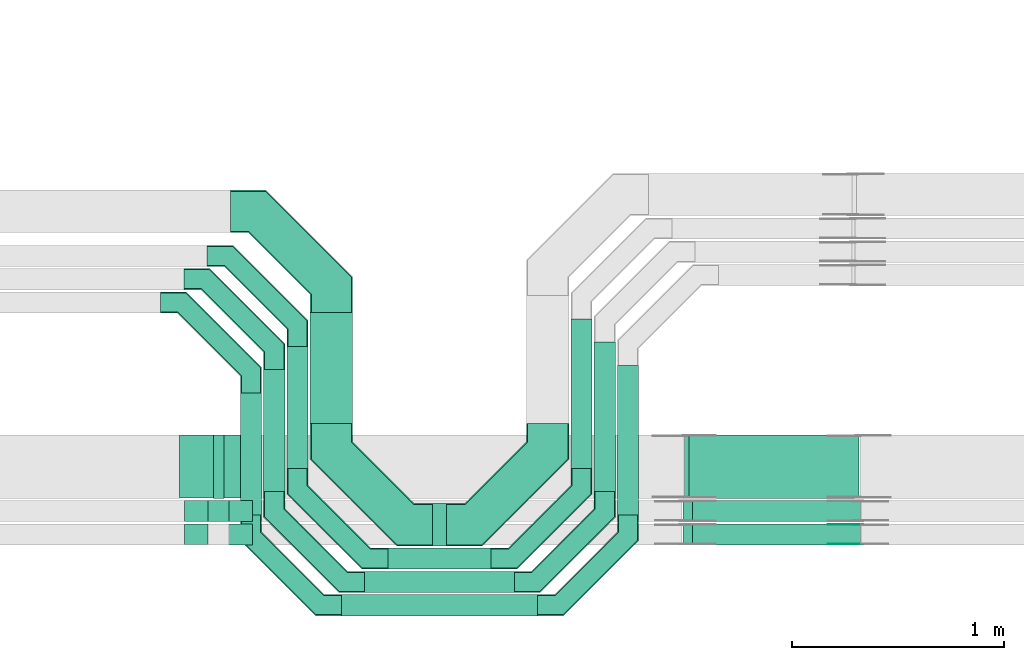
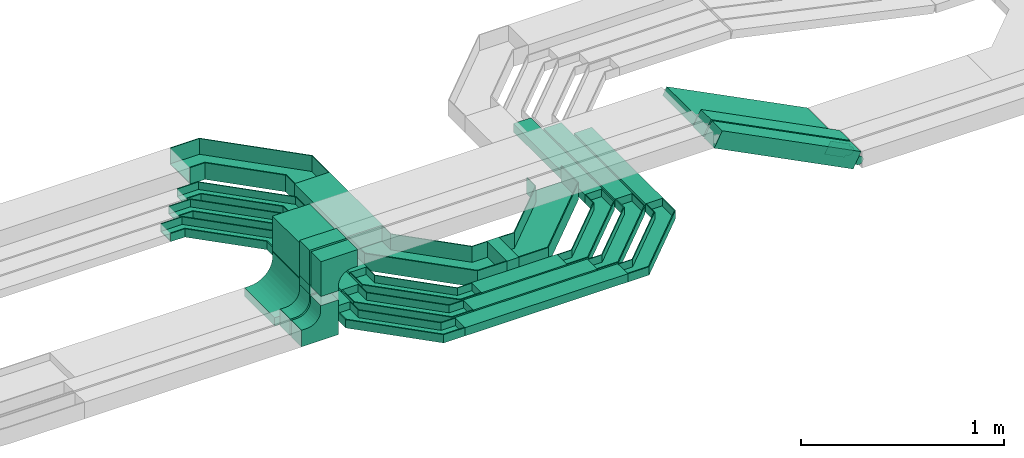
# One storey, part 14 of 33: 20 flow fittings, 16 flow segments.
"""IFC2X3 building model written with IfcOpenShell, lengths in millimetres."""

import ifcopenshell
import ifcopenshell.guid

model = None  # the IFC model being written
_history = None  # IfcOwnerHistory: only IFC2X3 demands one
_inside = {}  # id of a spatial element -> (the spatial element, [elements in it])
_under = {}  # id of a project, library or spatial element -> (it, [spatial elements below it])
_declared = {}  # id of a project -> (the project, [libraries it declares])
_typed = {}  # id of a type object -> (the type object, [elements of that type])
_made_of = {}  # id of a material, layer set ... -> (it, [elements and type objects made of it])


def new_model(schema):
    """Start an empty IFC model of exactly this schema.

    Asked for "IFC4X3", IfcOpenShell would pick the latest addendum, in which some entities
    have other attributes; the version numbers below select the first issue.
    IFC2X3 requires an IfcOwnerHistory on every rooted entity: one is made here for all.
    """
    global model, _history
    if schema == "IFC4X3":
        model = ifcopenshell.file(schema_version=(4, 3, 0, 0))
    else:
        model = ifcopenshell.file(schema=schema)
    _inside.clear()
    _under.clear()
    _declared.clear()
    _typed.clear()
    _made_of.clear()
    _history = None
    if model.schema == "IFC2X3":
        org = make("IfcOrganization", Name="unknown")
        user = make(
            "IfcPersonAndOrganization",
            ThePerson=make("IfcPerson", FamilyName="unknown"),
            TheOrganization=org,
        )
        app = make(
            "IfcApplication",
            ApplicationDeveloper=org,
            Version="unknown",
            ApplicationFullName="unknown",
            ApplicationIdentifier="unknown",
        )
        _history = make(
            "IfcOwnerHistory",
            OwningUser=user,
            OwningApplication=app,
            ChangeAction="ADDED",
            CreationDate=0,
        )
    return model


def make(cls, **values):
    """One entity of the class cls with the attributes given. An attribute that is None is left unset."""
    return model.create_entity(
        cls, **{name: value for name, value in values.items() if value is not None}
    )


def entity(cls, *values):
    """Any entity or typed value of the class cls, its attributes in the order of the schema. None: left unset."""
    e = model.create_entity(cls)
    for i, value in enumerate(values):
        if value is not None:
            e[i] = value
    return e


def rooted(cls, **values):
    """An entity with a GlobalId (a new one), such as an element, a storey or a relation."""
    return make(cls, GlobalId=ifcopenshell.guid.new(), OwnerHistory=_history, **values)


def si_unit(unit_type, name, prefix=None):
    """IfcSIUnit, for example si_unit("LENGTHUNIT", "METRE", prefix="MILLI")."""
    return make("IfcSIUnit", UnitType=unit_type, Prefix=prefix, Name=name)


def converted_unit(unit_type, name, factor, base, dimensions=None, offset=None):
    """IfcConversionBasedUnit, such as the inch: factor (a typed value) times the base unit."""
    return make(
        "IfcConversionBasedUnit"
        if offset is None
        else "IfcConversionBasedUnitWithOffset",
        ConversionOffset=offset,
        Dimensions=None
        if dimensions is None
        else entity("IfcDimensionalExponents", *dimensions),
        UnitType=unit_type,
        Name=name,
        ConversionFactor=make(
            "IfcMeasureWithUnit", ValueComponent=factor, UnitComponent=base
        ),
    )


def derived_unit(unit_type, elements):
    """IfcDerivedUnit: a product of units, each with its exponent."""
    return make(
        "IfcDerivedUnit",
        Elements=[
            make("IfcDerivedUnitElement", Unit=unit, Exponent=power)
            for unit, power in elements
        ],
        UnitType=unit_type,
    )


def assignment(units):
    """IfcUnitAssignment: the units of a project."""
    return None if units is None else make("IfcUnitAssignment", Units=units)


def point(xyz):
    """IfcCartesianPoint."""
    return None if xyz is None else make("IfcCartesianPoint", Coordinates=xyz)


def direction(xyz):
    """IfcDirection."""
    return None if xyz is None else make("IfcDirection", DirectionRatios=xyz)


def frame(location, z_axis=None, x_axis=None):
    """IfcAxis2Placement3D, a coordinate frame: its origin and axes. An axis left out is left unset."""
    return make(
        "IfcAxis2Placement3D",
        Location=point(location),
        Axis=direction(z_axis),
        RefDirection=direction(x_axis),
    )


def frame_2d(location, x_axis=None):
    """IfcAxis2Placement2D, a coordinate frame in the plane: its origin and x axis."""
    return make(
        "IfcAxis2Placement2D", Location=point(location), RefDirection=direction(x_axis)
    )


def origin():
    """The frame at (0, 0, 0) with its axes left unset."""
    return frame((0.0, 0.0, 0.0))


def origin_2d_with_axis():
    """The frame at (0, 0) in the plane with the x axis (1, 0) written out."""
    return frame_2d((0.0, 0.0), x_axis=(1.0, 0.0))


def place(relative_to, where):
    """IfcLocalPlacement: puts the frame where relative to a parent placement (None: the world)."""
    return make(
        "IfcLocalPlacement", PlacementRelTo=relative_to, RelativePlacement=where
    )


def context(
    kind, dimensions, precision=None, world=None, true_north=None, identifier=None
):
    """IfcGeometricRepresentationContext, for example the 3D "Model" context."""
    return make(
        "IfcGeometricRepresentationContext",
        ContextIdentifier=identifier,
        ContextType=kind,
        CoordinateSpaceDimension=dimensions,
        Precision=precision,
        WorldCoordinateSystem=world,
        TrueNorth=true_north,
    )


def subcontext(parent, identifier, kind, view, scale=None):
    """IfcGeometricRepresentationSubContext, for example "Body" below "Model"."""
    return make(
        "IfcGeometricRepresentationSubContext",
        ContextIdentifier=identifier,
        ContextType=kind,
        ParentContext=parent,
        TargetScale=scale,
        TargetView=view,
    )


def project(units=None, contexts=None):
    """IfcProject with its units and contexts."""
    return rooted(
        "IfcProject",
        Name="project",
        RepresentationContexts=contexts,
        UnitsInContext=assignment(units),
    )


def spatial(cls, under=None, at=None, **own):
    """A site, building, storey or space (cls), placed at a placement, below another one or the project."""
    s = rooted(cls, ObjectPlacement=at, **own)
    if under is not None:
        _under.setdefault(under.id(), (under, []))[1].append(s)
    return s


def polyline(points):
    """IfcPolyline through the points."""
    return make("IfcPolyline", Points=[point(p) for p in points])


def circle_curve(where, radius):
    """IfcCircle in the frame where."""
    return make("IfcCircle", Position=where, Radius=radius)


def parameter(value):
    """IfcParameterValue: where a trimmed curve begins or ends, as a parameter of its basis curve."""
    return model.create_entity("IfcParameterValue", value)


def trimmed(basis, trim1, trim2, sense, master):
    """IfcTrimmedCurve: the piece of a basis curve between two trims."""
    return make(
        "IfcTrimmedCurve",
        BasisCurve=basis,
        Trim1=trim1,
        Trim2=trim2,
        SenseAgreement=sense,
        MasterRepresentation=master,
    )


def segment(curve, same_sense, transition):
    """IfcCompositeCurveSegment."""
    return make(
        "IfcCompositeCurveSegment",
        Transition=transition,
        SameSense=same_sense,
        ParentCurve=curve,
    )


def composite_curve(segments, self_intersect=None):
    """IfcCompositeCurve: segments joined end to end."""
    return make("IfcCompositeCurve", Segments=segments, SelfIntersect=self_intersect)


def profile(cls, at=None, kind="AREA", **sizes):
    """A parametric profile (cls). Its sizes go by their IFC names, for example OverallWidth=200.0."""
    return make(cls, ProfileType=kind, Position=at, **sizes)


def rectangle(**sizes):
    """IfcRectangleProfileDef."""
    return profile("IfcRectangleProfileDef", **sizes)


def outline(outer, holes=None, kind="AREA"):
    """IfcArbitraryClosedProfileDef: a profile drawn as a closed curve; with holes, ...WithVoids."""
    if holes is None:
        return make("IfcArbitraryClosedProfileDef", ProfileType=kind, OuterCurve=outer)
    return make(
        "IfcArbitraryProfileDefWithVoids",
        ProfileType=kind,
        OuterCurve=outer,
        InnerCurves=holes,
    )


def extrude(swept, where, along, depth):
    """IfcExtrudedAreaSolid: the profile swept, set in the frame where, extruded along a direction by depth."""
    return make(
        "IfcExtrudedAreaSolid",
        SweptArea=swept,
        Position=where,
        ExtrudedDirection=direction(along),
        Depth=depth,
    )


def faces_of(points, faces, orient=None, outer=None):
    """IfcFace entities. A face is a list of loops; a loop is a list of indices into points, from 0.

    orient and outer hold one flag for each loop. By default every Orientation is true, the
    first loop of a face is its IfcFaceOuterBound and the others are IfcFaceBound.
    """
    made = []
    for i, loops in enumerate(faces):
        bounds = []
        for j, loop in enumerate(loops):
            is_outer = j == 0 if outer is None else outer[i][j]
            bounds.append(
                make(
                    "IfcFaceOuterBound" if is_outer else "IfcFaceBound",
                    Bound=make("IfcPolyLoop", Polygon=[points[k] for k in loop]),
                    Orientation=True if orient is None else orient[i][j],
                )
            )
        made.append(make("IfcFace", Bounds=bounds))
    return made


def faceted_brep(points, faces, orient=None, outer=None, voids=None):
    """IfcFacetedBrep: a solid bounded by flat faces; with voids (closed shells), ...WithVoids."""
    shared = [point(p) for p in points]
    hull = make("IfcClosedShell", CfsFaces=faces_of(shared, faces, orient, outer))
    if voids is None:
        return make("IfcFacetedBrep", Outer=hull)
    return make(
        "IfcFacetedBrepWithVoids",
        Outer=hull,
        Voids=[
            make(cls, CfsFaces=faces_of(shared, fs, o, b)) for cls, fs, o, b in voids
        ],
    )


def shape(context_of_items, identifier, shape_type, items):
    """IfcShapeRepresentation: the items that make up one representation, for example the "Body"."""
    return make(
        "IfcShapeRepresentation",
        ContextOfItems=context_of_items,
        RepresentationIdentifier=identifier,
        RepresentationType=shape_type,
        Items=items,
    )


def source(mapping_origin, context_of_items, identifier, shape_type, items):
    """IfcRepresentationMap: a shape defined once, which mapped items show again and again."""
    return make(
        "IfcRepresentationMap",
        MappingOrigin=mapping_origin,
        MappedRepresentation=shape(context_of_items, identifier, shape_type, items),
    )


def transform(
    local_origin,
    x_axis=None,
    y_axis=None,
    z_axis=None,
    scale=None,
    scale2=None,
    scale3=None,
    uniform=True,
):
    """IfcCartesianTransformationOperator3D, or its non-uniform kind. x_axis, y_axis, z_axis: its Axis1, 2, 3."""
    if uniform:
        return make(
            "IfcCartesianTransformationOperator3D",
            Axis1=direction(x_axis),
            Axis2=direction(y_axis),
            LocalOrigin=point(local_origin),
            Scale=scale,
            Axis3=direction(z_axis),
        )
    return make(
        "IfcCartesianTransformationOperator3DnonUniform",
        Axis1=direction(x_axis),
        Axis2=direction(y_axis),
        LocalOrigin=point(local_origin),
        Scale=scale,
        Axis3=direction(z_axis),
        Scale2=scale2,
        Scale3=scale3,
    )


def mapped(mapping_source, mapping_target):
    """IfcMappedItem: shows the shape of a source again, moved by a transform."""
    return make(
        "IfcMappedItem", MappingSource=mapping_source, MappingTarget=mapping_target
    )


def material(Name=None, Category=None):
    """IfcMaterial."""
    return make("IfcMaterial", Name=Name, Category=Category)


def made_of(thing, what):
    """Note that an element or type object is made of a material, layer set ...; save() writes the relation."""
    if what is not None:
        _made_of.setdefault(what.id(), (what, []))[1].append(thing)
    return thing


def type_object(cls, material=None, **own):
    """A type object (cls), such as IfcWallType, which elements share."""
    return made_of(rooted(cls, **own), material)


def type_shapes(of_type, sources):
    """Give a type object the sources (RepresentationMaps) that its elements show as mapped items."""
    of_type.RepresentationMaps = sources


def element(
    cls,
    number,
    at=None,
    inside=None,
    cuts=None,
    type_object=None,
    material=None,
    context=None,
    identifier="Body",
    shape_type=None,
    held_by="IfcProductDefinitionShape",
    body=None,
    shapes=None,
    **own,
):
    """One element of the class cls, such as IfcWall. Its Tag is "e" and its number.

    at: its placement. inside: the storey or other place that contains it. cuts: it is an
    opening in that element (IfcRelVoidsElement). A single representation is given by context,
    identifier, shape_type and body (its items); several are given by shapes. held_by: the class
    of the entity that holds the representations. save() writes the other relations.
    """
    e = rooted(cls, Tag="e%d" % number, ObjectPlacement=at, **own)
    if body is not None:
        shapes = [shape(context, identifier, shape_type, body)]
    if shapes is not None:
        e.Representation = make(held_by, Representations=shapes)
    if inside is not None:
        _inside.setdefault(inside.id(), (inside, []))[1].append(e)
    if cuts is not None:
        rooted(
            "IfcRelVoidsElement", RelatingBuildingElement=cuts, RelatedOpeningElement=e
        )
    if type_object is not None:
        _typed.setdefault(type_object.id(), (type_object, []))[1].append(e)
    return made_of(e, material)


def aggregate(whole, parts):
    """IfcRelAggregates: a whole, such as a stair, and the parts it consists of."""
    return rooted("IfcRelAggregates", RelatingObject=whole, RelatedObjects=parts)


def save(model, path):
    """Write the relations noted so far, then the file.

    IfcRelAggregates (storeys below a building ...), IfcRelContainedInSpatialStructure (elements
    in a storey), IfcRelDefinesByType, IfcRelAssociatesMaterial and IfcRelDeclares: one each for
    every whole, place, type object, material and project.
    """
    for whole, parts in _under.values():
        aggregate(whole, parts)
    for where, things in _inside.values():
        rooted(
            "IfcRelContainedInSpatialStructure",
            RelatedElements=things,
            RelatingStructure=where,
        )
    for kind, things in _typed.values():
        rooted("IfcRelDefinesByType", RelatedObjects=things, RelatingType=kind)
    for what, things in _made_of.values():
        rooted("IfcRelAssociatesMaterial", RelatedObjects=things, RelatingMaterial=what)
    for by, libraries in _declared.values():
        rooted("IfcRelDeclares", RelatingContext=by, RelatedDefinitions=libraries)
    model.write(path)


model = new_model("IFC2X3")

# Units and contexts
model_context = context("Model", 3, precision=0.01, world=origin(), true_north=direction((6.12303176911189e-17, 1.0)))
body_context = subcontext(model_context, "Body", "Model", "MODEL_VIEW")
ifc_project = project(units=[si_unit("LENGTHUNIT", "METRE", prefix="MILLI"), si_unit("AREAUNIT", "SQUARE_METRE"), si_unit("VOLUMEUNIT", "CUBIC_METRE"), converted_unit("PLANEANGLEUNIT", "DEGREE", entity("IfcRatioMeasure", 0.0174532925199433), si_unit("PLANEANGLEUNIT", "RADIAN"), dimensions=[0, 0, 0, 0, 0, 0, 0]), si_unit("MASSUNIT", "GRAM", prefix="KILO"), derived_unit("MASSDENSITYUNIT", [(si_unit("MASSUNIT", "GRAM", prefix="KILO"), 1), (si_unit("LENGTHUNIT", "METRE"), -3)]), derived_unit("MOMENTOFINERTIAUNIT", [(si_unit("LENGTHUNIT", "METRE"), 4)]), si_unit("TIMEUNIT", "SECOND"), si_unit("FREQUENCYUNIT", "HERTZ"), si_unit("THERMODYNAMICTEMPERATUREUNIT", "DEGREE_CELSIUS"), derived_unit("THERMALTRANSMITTANCEUNIT", [(si_unit("MASSUNIT", "GRAM", prefix="KILO"), 1), (si_unit("THERMODYNAMICTEMPERATUREUNIT", "KELVIN"), -1), (si_unit("TIMEUNIT", "SECOND"), -3)]), derived_unit("VOLUMETRICFLOWRATEUNIT", [(si_unit("LENGTHUNIT", "METRE"), 3), (si_unit("TIMEUNIT", "SECOND"), -1)]), derived_unit("MASSFLOWRATEUNIT", [(si_unit("MASSUNIT", "GRAM", prefix="KILO"), 1), (si_unit("TIMEUNIT", "SECOND"), -1)]), derived_unit("ROTATIONALFREQUENCYUNIT", [(si_unit("TIMEUNIT", "SECOND"), -1)]), si_unit("ELECTRICCURRENTUNIT", "AMPERE"), si_unit("ELECTRICVOLTAGEUNIT", "VOLT"), si_unit("POWERUNIT", "WATT"), si_unit("FORCEUNIT", "NEWTON", prefix="KILO"), si_unit("ILLUMINANCEUNIT", "LUX"), si_unit("LUMINOUSFLUXUNIT", "LUMEN"), si_unit("LUMINOUSINTENSITYUNIT", "CANDELA"), derived_unit("USERDEFINED", [(si_unit("MASSUNIT", "GRAM", prefix="KILO"), -1), (si_unit("LENGTHUNIT", "METRE"), -2), (si_unit("TIMEUNIT", "SECOND"), 3), (si_unit("LUMINOUSFLUXUNIT", "LUMEN"), 1)]), derived_unit("LINEARVELOCITYUNIT", [(si_unit("LENGTHUNIT", "METRE"), 1), (si_unit("TIMEUNIT", "SECOND"), -1)]), si_unit("PRESSUREUNIT", "PASCAL"), derived_unit("USERDEFINED", [(si_unit("LENGTHUNIT", "METRE"), -2), (si_unit("MASSUNIT", "GRAM", prefix="KILO"), 1), (si_unit("TIMEUNIT", "SECOND"), -2)]), derived_unit("LINEARFORCEUNIT", [(si_unit("MASSUNIT", "GRAM", prefix="KILO"), 1), (si_unit("LENGTHUNIT", "METRE"), 1), (si_unit("TIMEUNIT", "SECOND"), -2), (si_unit("LENGTHUNIT", "METRE"), -1)]), derived_unit("PLANARFORCEUNIT", [(si_unit("MASSUNIT", "GRAM", prefix="KILO"), 1), (si_unit("LENGTHUNIT", "METRE"), 1), (si_unit("TIMEUNIT", "SECOND"), -2), (si_unit("LENGTHUNIT", "METRE"), -2)])], contexts=[model_context])

# Site, building, storey
site_placement = place(None, frame((0.0, -0.00077364408347762, 0.0)))
site = spatial("IfcSite", under=ifc_project, at=site_placement, CompositionType="ELEMENT")
building_placement = place(site_placement, origin())
building = spatial("IfcBuilding", under=site, at=building_placement, CompositionType="ELEMENT")
storey_placement = place(building_placement, frame((0.0, 0.0, 8100.0)))
storey = spatial("IfcBuildingStorey", under=building, at=storey_placement, CompositionType="ELEMENT", Elevation=8100.0)

# Flow segments
cable_carrier_segment_type = type_object("IfcCableCarrierSegmentType", PredefinedType="CABLETRAYSEGMENT")
flow_segment_1_placement = place(storey_placement, frame((30337.4684005989, 8308.01799859667, 2800.0)))
element("IfcFlowSegment", 1, at=flow_segment_1_placement, inside=storey, type_object=cable_carrier_segment_type, context=body_context, shape_type="SweptSolid", body=[
    extrude(rectangle(XDim=487.314922946357, YDim=100.000000000001, at=frame_2d((-2.1600499167107e-12, 0.0), x_axis=(1.0, 0.0))), frame((243.65746147318, 50.0, 0.0)), (0.0, 0.0, 1.0), 50.0000000000016),
])
flow_segment_2_placement = place(storey_placement, frame((30227.9450437435, 8198.49464174137, 2800.0)))
element("IfcFlowSegment", 2, at=flow_segment_2_placement, inside=storey, type_object=cable_carrier_segment_type, context=body_context, shape_type="SweptSolid", body=[
    extrude(rectangle(XDim=706.36163665698, YDim=99.9999999999989, at=frame_2d((2.1600499167107e-12, -5.40012479177676e-13), x_axis=(1.0, 0.0))), frame((353.180818328488, 50.0, 0.0)), (0.0, 0.0, 1.0), 50.0000000000016),
])
flow_segment_3_placement = place(storey_placement, frame((30117.9450437435, 8088.49464174135, 2800.0)))
element("IfcFlowSegment", 3, at=flow_segment_3_placement, inside=storey, type_object=cable_carrier_segment_type, context=body_context, shape_type="SweptSolid", body=[
    extrude(rectangle(XDim=926.361636657043, YDim=99.9999999999989, at=frame_2d((-2.1600499167107e-12, -5.40012479177676e-13), x_axis=(1.0, 0.0))), frame((463.180818328524, 50.0, 0.0)), (0.0, 0.0, 1.0), 50.0000000000016),
])
flow_segment_4_placement = place(storey_placement, frame((30547.4684005988, 8418.01799859664, 2800.0)))
element("IfcFlowSegment", 4, at=flow_segment_4_placement, inside=storey, type_object=cable_carrier_segment_type, context=body_context, shape_type="SweptSolid", body=[
    extrude(rectangle(XDim=67.3149229463092, YDim=200.0, at=frame_2d((-4.33075797445781e-12, -5.47117906535277e-13), x_axis=(1.0, 0.0))), frame((33.6574614731676, 100.0, 0.0)), (0.0, 0.0, 1.0), 99.9999999999989),
])
flow_segment_5_placement = place(storey_placement, frame((29489.4603210585, 8532.45182054437, 2999.66918252172)))
element("IfcFlowSegment", 5, at=flow_segment_5_placement, inside=storey, type_object=cable_carrier_segment_type, context=body_context, shape_type="SweptSolid", body=[
    extrude(rectangle(XDim=100.000000000001, YDim=100.000000000003, at=frame_2d((1.08357767203415e-12, -4.33431068813661e-12), x_axis=(1.0, 0.0))), frame((50.0, 50.0, 0.0), z_axis=(0.0, 0.0, 1.0), x_axis=(0.0, 1.0, 0.0)), (0.0, 0.0, 1.0), 55.3479418970819),
])
flow_segment_6_placement = place(storey_placement, frame((29514.4603210585, 8642.0466811094, 3000.01530223365)))
element("IfcFlowSegment", 6, at=flow_segment_6_placement, inside=storey, type_object=cable_carrier_segment_type, context=body_context, shape_type="SweptSolid", body=[
    extrude(rectangle(XDim=299.999999999999, YDim=49.9999999999973, at=frame_2d((0.0, -4.33253433129721e-12), x_axis=(1.0, 0.0))), frame((25.0, 150.0, 0.0), z_axis=(0.0, 0.0, 1.0), x_axis=(0.0, 1.0, 0.0)), (0.0, 0.0, 1.0), 5.00181141795619),
])
flow_segment_7_placement = place(storey_placement, frame((29971.4684005989, 8994.01799859668, 2800.0)))
element("IfcFlowSegment", 7, at=flow_segment_7_placement, inside=storey, type_object=cable_carrier_segment_type, context=body_context, shape_type="SweptSolid", body=[
    extrude(rectangle(XDim=524.980554870058, YDim=199.999999999998, at=frame_2d((-5.40012479177676e-13, 2.16715534406831e-12), x_axis=(1.0, 0.0))), frame((100.0, 262.490277435048, 0.0), z_axis=(0.0, 0.0, 1.0), x_axis=(0.0, 1.0, 0.0)), (0.0, 0.0, 1.0), 99.9999999999989),
])
flow_segment_8_placement = place(storey_placement, frame((29861.4684005989, 8784.01799859668, 2800.0)))
element("IfcFlowSegment", 8, at=flow_segment_8_placement, inside=storey, type_object=cable_carrier_segment_type, context=body_context, shape_type="SweptSolid", body=[
    extrude(rectangle(XDim=574.980554870002, YDim=100.000000000003, at=origin_2d_with_axis()), frame((50.0, 287.490277435006, 0.0), z_axis=(0.0, 0.0, 1.0), x_axis=(0.0, 1.0, 0.0)), (0.0, 0.0, 1.0), 50.0000000000016),
])
flow_segment_9_placement = place(storey_placement, frame((29751.9450437435, 8674.49464174137, 2800.0)))
element("IfcFlowSegment", 9, at=flow_segment_9_placement, inside=storey, type_object=cable_carrier_segment_type, context=body_context, shape_type="SweptSolid", body=[
    extrude(rectangle(XDim=574.980554869993, YDim=100.000000000003, at=frame_2d((5.40012479177676e-13, -2.16715534406831e-12), x_axis=(1.0, 0.0))), frame((50.0, 287.490277435002, 0.0), z_axis=(0.0, 0.0, 1.0), x_axis=(0.0, 1.0, 0.0)), (0.0, 0.0, 1.0), 50.0000000000016),
])
flow_segment_10_placement = place(storey_placement, frame((29641.9450437435, 8564.49464174135, 2800.0)))
element("IfcFlowSegment", 10, at=flow_segment_10_placement, inside=storey, type_object=cable_carrier_segment_type, context=body_context, shape_type="SweptSolid", body=[
    extrude(rectangle(XDim=574.98055487001, YDim=100.000000000003, at=frame_2d((5.40012479177676e-13, -2.16715534406831e-12), x_axis=(1.0, 0.0))), frame((50.0, 287.490277435011, 0.0), z_axis=(0.0, 0.0, 1.0), x_axis=(0.0, 1.0, 0.0)), (0.0, 0.0, 1.0), 50.0000000000016),
])
flow_segment_11_placement = place(storey_placement, frame((31200.7833235452, 8784.01799859666, 2800.0)))
element("IfcFlowSegment", 11, at=flow_segment_11_placement, inside=storey, type_object=cable_carrier_segment_type, context=body_context, shape_type="SweptSolid", body=[
    extrude(rectangle(XDim=704.980554870133, YDim=100.000000000003, at=frame_2d((-5.40012479177676e-13, -2.16715534406831e-12), x_axis=(1.0, 0.0))), frame((50.0, 352.490277435071, 0.0), z_axis=(0.0, 0.0, 1.0), x_axis=(0.0, 1.0, 0.0)), (0.0, 0.0, 1.0), 50.0000000000016),
])
flow_segment_12_placement = place(storey_placement, frame((31310.3066804005, 8674.49464174137, 2800.0)))
element("IfcFlowSegment", 12, at=flow_segment_12_placement, inside=storey, type_object=cable_carrier_segment_type, context=body_context, shape_type="SweptSolid", body=[
    extrude(rectangle(XDim=704.50391172545, YDim=100.000000000003, at=frame_2d((0.0, -2.16715534406831e-12), x_axis=(1.0, 0.0))), frame((50.0, 352.251955862729, 0.0), z_axis=(0.0, 0.0, 1.0), x_axis=(0.0, 1.0, 0.0)), (0.0, 0.0, 1.0), 50.0000000000016),
])
flow_segment_13_placement = place(storey_placement, frame((31420.3066804005, 8564.49464174134, 2800.0)))
element("IfcFlowSegment", 13, at=flow_segment_13_placement, inside=storey, type_object=cable_carrier_segment_type, context=body_context, shape_type="SweptSolid", body=[
    extrude(rectangle(XDim=704.50391172544, YDim=100.000000000003, at=frame_2d((-5.40012479177676e-13, 0.0), x_axis=(1.0, 0.0))), frame((50.0, 352.251955862725, 0.0), z_axis=(0.0, 0.0, 1.0), x_axis=(0.0, 1.0, 0.0)), (0.0, 0.0, 1.0), 50.0000000000016),
])
flow_segment_14_placement = place(storey_placement, frame((31729.2160235265, 8422.4518205444, 2761.04612304879)))
element("IfcFlowSegment", 14, at=flow_segment_14_placement, inside=storey, type_object=cable_carrier_segment_type, context=body_context, shape_type="SweptSolid", body=[
    extrude(rectangle(XDim=99.9999999999994, YDim=99.9999999999989, at=origin_2d_with_axis()), frame((22.6767827615152, 50.0, 446.925408334899), z_axis=(0.891238132843751, 0.0, -0.453535655230307), x_axis=(0.453535655230307, 0.0, 0.891238132843751)), (0.0, 0.0, 1.0), 887.170605116738),
])
flow_segment_15_placement = place(storey_placement, frame((31729.2162886322, 8532.45182054437, 2761.77523770316)))
element("IfcFlowSegment", 15, at=flow_segment_15_placement, inside=storey, type_object=cable_carrier_segment_type, context=body_context, shape_type="SweptSolid", body=[
    extrude(rectangle(XDim=100.000000000002, YDim=99.9999999999989, at=origin_2d_with_axis()), frame((22.6763184118082, 50.0, 446.915474721197), z_axis=(0.891242858773367, 0.0, -0.453526368236155), x_axis=(0.453526368236155, 0.0, 0.891242858773367)), (0.0, 0.0, 1.0), 887.166347895878),
])
flow_segment_16_placement = place(storey_placement, frame((31735.211445593, 8642.04668110939, 2756.34337321808)))
element("IfcFlowSegment", 16, at=flow_segment_16_placement, inside=storey, type_object=cable_carrier_segment_type, context=body_context, shape_type="SweptSolid", body=[
    extrude(rectangle(XDim=49.9999999999983, YDim=300.000000000001, at=origin_2d_with_axis()), frame((11.3380256243896, 150.0, 430.06634116416), z_axis=(0.891245577775935, 0.0, -0.453521024975513), x_axis=(0.453521024975513, 0.0, 0.891245577775935)), (0.0, 0.0, 1.0), 899.153907455076),
])

# Flow fittings
ifc_material_1 = material(Name="G")
cable_carrier_fitting_type_1 = type_object("IfcCableCarrierFittingType", PredefinedType="NOTDEFINED", material=ifc_material_1)
shared_shape_1 = source(origin(), body_context, "Body", "SweptSolid", [
    extrude(outline(composite_curve([segment(trimmed(circle_curve(frame_2d((-41.4651162790697, 0.0), x_axis=(1.0, 0.0)), 25.0), [parameter(90.0000000000007)], [parameter(270.0)], True, "PARAMETER"), True, "CONTINUOUS"), segment(polyline([(-41.4651162790697, -25.0), (-29.9651162790697, -25.0)]), True, "CONTINUOUS"), segment(polyline([(-29.9651162790697, -25.0), (-28.1046511627907, -38.5)]), True, "CONTINUOUS"), segment(polyline([(-28.1046511627907, -38.5), (99.5348837209303, -38.5)]), True, "CONTINUOUS"), segment(polyline([(99.5348837209303, -38.5), (99.5348837209303, 38.5)]), True, "CONTINUOUS"), segment(polyline([(99.5348837209303, 38.5), (-28.1046511627907, 38.5)]), True, "CONTINUOUS"), segment(polyline([(-28.1046511627907, 38.5), (-29.9651162790697, 25.0)]), True, "CONTINUOUS"), segment(polyline([(-29.9651162790697, 25.0), (-41.46511627907, 25.0)]), True, "CONTINUOUS")], self_intersect=False)), frame((41.4651162790697, 0.0, 0.0), z_axis=(0.0, 0.0, -1.0), x_axis=(1.0, 0.0, 0.0)), (0.0, 0.0, -1.0), 2.0),
])
type_shapes(cable_carrier_fitting_type_1, [shared_shape_1])
flow_fitting_1_placement = place(storey_placement, frame((32555.0055651355, 8517.91182055455, 2799.2813532093), z_axis=(0.0, 1.0, 0.0), x_axis=(-0.891238132843699, 0.0, 0.45353565523041)))
element("IfcFlowFitting", 17, at=flow_fitting_1_placement, inside=storey, type_object=cable_carrier_fitting_type_1, material=ifc_material_1, context=body_context, shape_type="MappedRepresentation", body=[
    mapped(shared_shape_1, transform((0.0, 0.0, 0.0), scale=1.0)),
])
cable_carrier_fitting_type_2 = type_object("IfcCableCarrierFittingType", PredefinedType="NOTDEFINED", material=ifc_material_1)
shared_shape_2 = source(origin(), body_context, "Body", "SweptSolid", [
    extrude(outline(composite_curve([segment(trimmed(circle_curve(frame_2d((-41.4651162790697, 0.0), x_axis=(1.0, 0.0)), 25.0), [parameter(90.0000000000007)], [parameter(270.0)], True, "PARAMETER"), True, "CONTINUOUS"), segment(polyline([(-41.4651162790697, -25.0), (-29.9651162790697, -25.0)]), True, "CONTINUOUS"), segment(polyline([(-29.9651162790697, -25.0), (-28.1046511627907, -38.5)]), True, "CONTINUOUS"), segment(polyline([(-28.1046511627907, -38.5), (99.5348837209303, -38.5)]), True, "CONTINUOUS"), segment(polyline([(99.5348837209303, -38.5), (99.5348837209303, 38.5)]), True, "CONTINUOUS"), segment(polyline([(99.5348837209303, 38.5), (-28.1046511627907, 38.5)]), True, "CONTINUOUS"), segment(polyline([(-28.1046511627907, 38.5), (-29.9651162790697, 25.0)]), True, "CONTINUOUS"), segment(polyline([(-29.9651162790697, 25.0), (-41.46511627907, 25.0)]), True, "CONTINUOUS")], self_intersect=False)), frame((41.4651162790697, 0.0, 0.0)), (0.0, 0.0, 1.0), 2.0),
])
type_shapes(cable_carrier_fitting_type_2, [shared_shape_2])
flow_fitting_2_placement = place(storey_placement, frame((32555.0055651355, 8426.99182053424, 2799.28135320929), z_axis=(0.0, -1.0, 0.0), x_axis=(-0.891238132843699, 0.0, 0.45353565523041)))
element("IfcFlowFitting", 18, at=flow_fitting_2_placement, inside=storey, type_object=cable_carrier_fitting_type_2, material=ifc_material_1, context=body_context, shape_type="MappedRepresentation", body=[
    mapped(shared_shape_2, transform((0.0, 0.0, 0.0), scale=1.0)),
])
ifc_material_2 = material()
cable_carrier_fitting_type_3 = type_object("IfcCableCarrierFittingType", Name="470_DKC_S5_CDV 90 external vertical angle:-", PredefinedType="NOTDEFINED", material=ifc_material_2)
shared_shape_3 = source(origin(), body_context, "Body", "SweptSolid", [
    extrude(outline(composite_curve([segment(polyline([(65.7142857142854, 14.2857142857149), (95.7142857142855, 14.2857142857149)]), True, "CONTINUOUS"), segment(polyline([(95.7142857142855, 14.2857142857149), (95.7142857142855, 114.285714285713)]), True, "CONTINUOUS"), segment(polyline([(95.7142857142855, 114.285714285713), (-114.285714285714, 114.285714285713)]), True, "CONTINUOUS"), segment(polyline([(-114.285714285714, 114.285714285713), (-114.285714285714, -95.7142857142853)]), True, "CONTINUOUS"), segment(polyline([(-114.285714285714, -95.7142857142853), (-14.2857142857144, -95.7142857142853)]), True, "CONTINUOUS"), segment(polyline([(-14.2857142857145, -95.7142857142853), (-14.2857142857145, -65.7142857142849)]), True, "CONTINUOUS"), segment(trimmed(circle_curve(frame_2d((65.7142857142855, -65.714285714285), x_axis=(-1.0, 0.0)), 80.0), [parameter(270.0)], [parameter(2.54444374517082e-13)], True, "PARAMETER"), False, "CONTINUOUS")], self_intersect=False)), frame((-64.2857142857073, 64.2857142857068, -49.0), z_axis=(0.0, 0.0, 1.0), x_axis=(-1.0, 0.0, 0.0)), (0.0, 0.0, 1.0), 99.0000000000002),
])
type_shapes(cable_carrier_fitting_type_3, [shared_shape_3])
for number, where, z_axis, x_axis, name in (
    (19, (29539.4603210585, 8472.4518205444, 3214.29820786533), (0.0, -1.0, 0.0), (-1.0, 0.0, 0.0), "470_DKC_S5_90 external vertical angle"),
    (20, (29539.4603210585, 8582.45182054437, 3215.01712441882), (0.0, 1.0, 0.0), (0.0, 0.0, 1.0), "470_DKC_S5_90 external vertical angle"),
):
    element("IfcFlowFitting", number, at=place(storey_placement, frame(where, z_axis=z_axis, x_axis=x_axis)), inside=storey, type_object=cable_carrier_fitting_type_3, material=ifc_material_2, Name=name, ObjectType="470_DKC_S5_CDV 90 external vertical angle:-", context=body_context, shape_type="MappedRepresentation", body=[
        mapped(shared_shape_3, transform((0.0, 0.0, 0.0), scale=1.0)),
    ])
cable_carrier_fitting_type_4 = type_object("IfcCableCarrierFittingType", Name="470_DKC_G5_Sheet horizontal bend:-", PredefinedType="NOTDEFINED", material=ifc_material_2)
shared_shape_4 = source(origin(), body_context, "Body", "Brep", [
    faceted_brep([(-476.0, -100.0, -50.0), (-476.0, -100.0, 50.0), (-476.0, -95.0, 50.0), (-476.0, -95.0, -45.0), (-476.0, 95.0, -45.0), (-476.0, 95.0, 50.0), (-476.0, 100.0, 50.0), (-476.0, 100.0, -50.0), (100.0, 476.0, -50.0), (-100.0, 476.0, -50.0), (-100.0, 476.0, 50.0), (-95.0, 476.0, 50.0), (-95.0, 476.0, -45.0), (95.0, 476.0, -45.0), (95.0, 476.0, 50.0), (100.0, 476.0, 50.0), (-308.578643762682, -100.0, -50.0), (-308.578643762682, -100.0, 50.0), (100.0, 308.578643762679, 50.0), (95.0, 310.649711574545, 50.0), (-310.649711574548, -95.0, 50.0), (-310.649711574548, -95.0, -45.0), (95.0, 310.649711574545, -45.0), (-95.0, 389.350288425433, -45.0), (-389.350288425436, 95.0, -45.0), (-389.350288425436, 95.0, 50.0), (-95.0, 389.350288425433, 50.0), (-100.0, 391.421356237299, 50.0), (-391.421356237301, 100.0, 50.0), (-391.421356237301, 100.0, -50.0), (-100.0, 391.421356237298, -50.0), (100.0, 308.57864376268, -50.0)], [[[0, 1, 2, 3, 4, 5, 6, 7]], [[8, 9, 10, 11, 12, 13, 14, 15]], [[1, 0, 16, 17]], [[2, 1, 17, 18, 15, 14, 19, 20]], [[3, 2, 20, 21]], [[4, 3, 21, 22, 13, 12, 23, 24]], [[5, 4, 24, 25]], [[6, 5, 25, 26, 11, 10, 27, 28]], [[7, 6, 28, 29]], [[0, 7, 29, 30, 9, 8, 31, 16]], [[17, 16, 31, 18]], [[21, 20, 19, 22]], [[25, 24, 23, 26]], [[29, 28, 27, 30]], [[18, 31, 8, 15]], [[22, 19, 14, 13]], [[26, 23, 12, 11]], [[30, 27, 10, 9]]]),
])
type_shapes(cable_carrier_fitting_type_4, [shared_shape_4])
for number, where, z_axis, x_axis, name in (
    (21, (30071.4684005989, 8518.01799859671, 2850.0), (0.0, 0.0, 1.0), (0.0, -1.0, 0.0), "470_DKC_G5_Sheet horizontal bend:-"),
    (22, (30071.4684005989, 9994.99855346674, 2850.0), (0.0, 0.0, 1.0), (0.0, 1.0, 0.0), "470_DKC_G5_Sheet horizontal bend:-"),
):
    element("IfcFlowFitting", number, at=place(storey_placement, frame(where, z_axis=z_axis, x_axis=x_axis)), inside=storey, type_object=cable_carrier_fitting_type_4, material=ifc_material_2, Name=name, ObjectType="470_DKC_G5_Sheet horizontal bend:-", context=body_context, shape_type="MappedRepresentation", body=[
        mapped(shared_shape_4, transform((0.0, 0.0, 0.0), scale=1.0)),
    ])
flow_fitting_3_placement = place(storey_placement, frame((31090.7833235451, 8518.01799859666, 2850.0)))
element("IfcFlowFitting", 23, at=flow_fitting_3_placement, inside=storey, type_object=cable_carrier_fitting_type_4, material=ifc_material_2, Name="470_DKC_G5_Sheet horizontal bend:-", ObjectType="470_DKC_G5_Sheet horizontal bend:-", context=body_context, shape_type="MappedRepresentation", body=[
    mapped(shared_shape_4, transform((0.0, 0.0, 0.0), scale=1.0)),
])
cable_carrier_fitting_type_5 = type_object("IfcCableCarrierFittingType", Name="470_DKC_G5_Sheet horizontal bend:-", PredefinedType="NOTDEFINED", material=ifc_material_2)
shared_shape_5 = source(origin(), body_context, "Body", "Brep", [
    faceted_brep([(-426.0, -50.0, -25.0), (-426.0, -50.0, 25.0), (-426.0, -45.0, 25.0), (-426.0, -45.0, -20.0), (-426.0, 45.0, -20.0), (-426.0, 45.0, 25.0), (-426.0, 50.0, 25.0), (-426.0, 50.0, -25.0), (50.0, 426.0, -25.0), (-50.0, 426.0, -25.0), (-50.0, 426.0, 25.0), (-45.0, 426.0, 25.0), (-45.0, 426.0, -20.0), (45.0, 426.0, -20.0), (45.0, 426.0, 25.0), (50.0, 426.0, 25.0), (-304.289321881337, -50.0, -25.0), (-304.289321881337, -50.0, 25.0), (50.0, 304.289321881334, 25.0), (45.0, 306.3603896932, 25.0), (-306.360389693203, -45.0, 25.0), (-306.360389693203, -45.0, -20.0), (45.0, 306.3603896932, -20.0), (-45.0, 343.639610306778, -20.0), (-343.639610306781, 45.0, -20.0), (-343.639610306781, 45.0, 25.0), (-45.0, 343.639610306778, 25.0), (-50.0, 345.710678118644, 25.0), (-345.710678118647, 50.0, 25.0), (-345.710678118647, 50.0, -25.0), (-50.0, 345.710678118644, -25.0), (50.0, 304.289321881334, -25.0)], [[[0, 1, 2, 3, 4, 5, 6, 7]], [[8, 9, 10, 11, 12, 13, 14, 15]], [[1, 0, 16, 17]], [[2, 1, 17, 18, 15, 14, 19, 20]], [[3, 2, 20, 21]], [[4, 3, 21, 22, 13, 12, 23, 24]], [[5, 4, 24, 25]], [[6, 5, 25, 26, 11, 10, 27, 28]], [[7, 6, 28, 29]], [[0, 7, 29, 30, 9, 8, 31, 16]], [[17, 16, 31, 18]], [[21, 20, 19, 22]], [[25, 24, 23, 26]], [[29, 28, 27, 30]], [[18, 31, 8, 15]], [[22, 19, 14, 13]], [[26, 23, 12, 11]], [[30, 27, 10, 9]]]),
])
type_shapes(cable_carrier_fitting_type_5, [shared_shape_5])
for number, where, z_axis, x_axis, name in (
    (24, (29691.9450437436, 9565.47519661136, 2825.0), (0.0, 0.0, 1.0), (0.0, 1.0, 0.0), "470_DKC_G5_Sheet horizontal bend:-"),
    (25, (29801.9450437436, 9675.47519661136, 2825.0), (0.0, 0.0, 1.0), (0.0, 1.0, 0.0), "470_DKC_G5_Sheet horizontal bend:-"),
    (26, (29911.4684005989, 9784.99855346667, 2825.0), (0.0, 0.0, 1.0), (0.0, 1.0, 0.0), "470_DKC_G5_Sheet horizontal bend:-"),
    (27, (29911.4684005989, 8358.0179985967, 2825.0), (0.0, 0.0, 1.0), (0.0, -1.0, 0.0), "470_DKC_G5_Sheet horizontal bend:-"),
):
    element("IfcFlowFitting", number, at=place(storey_placement, frame(where, z_axis=z_axis, x_axis=x_axis)), inside=storey, type_object=cable_carrier_fitting_type_5, material=ifc_material_2, Name=name, ObjectType="470_DKC_G5_Sheet horizontal bend:-", context=body_context, shape_type="MappedRepresentation", body=[
        mapped(shared_shape_5, transform((0.0, 0.0, 0.0), scale=1.0)),
    ])
flow_fitting_4_placement = place(storey_placement, frame((31250.7833235452, 8358.01799859669, 2825.0)))
element("IfcFlowFitting", 28, at=flow_fitting_4_placement, inside=storey, type_object=cable_carrier_fitting_type_5, material=ifc_material_2, Name="470_DKC_G5_Sheet horizontal bend:-", ObjectType="470_DKC_G5_Sheet horizontal bend:-", context=body_context, shape_type="MappedRepresentation", body=[
    mapped(shared_shape_5, transform((0.0, 0.0, 0.0), scale=1.0)),
])
flow_fitting_5_placement = place(storey_placement, frame((29801.9450437436, 8248.49464174139, 2825.0), z_axis=(0.0, 0.0, 1.0), x_axis=(0.0, -1.0, 0.0)))
element("IfcFlowFitting", 29, at=flow_fitting_5_placement, inside=storey, type_object=cable_carrier_fitting_type_5, material=ifc_material_2, Name="470_DKC_G5_Sheet horizontal bend:-", ObjectType="470_DKC_G5_Sheet horizontal bend:-", context=body_context, shape_type="MappedRepresentation", body=[
    mapped(shared_shape_5, transform((0.0, 0.0, 0.0), scale=1.0)),
])
flow_fitting_6_placement = place(storey_placement, frame((31360.3066804005, 8248.49464174139, 2825.0)))
element("IfcFlowFitting", 30, at=flow_fitting_6_placement, inside=storey, type_object=cable_carrier_fitting_type_5, material=ifc_material_2, Name="470_DKC_G5_Sheet horizontal bend:-", ObjectType="470_DKC_G5_Sheet horizontal bend:-", context=body_context, shape_type="MappedRepresentation", body=[
    mapped(shared_shape_5, transform((0.0, 0.0, 0.0), scale=1.0)),
])
flow_fitting_7_placement = place(storey_placement, frame((29691.9450437435, 8138.49464174137, 2825.0), z_axis=(0.0, 0.0, 1.0), x_axis=(0.0, -1.0, 0.0)))
element("IfcFlowFitting", 31, at=flow_fitting_7_placement, inside=storey, type_object=cable_carrier_fitting_type_5, material=ifc_material_2, Name="470_DKC_G5_Sheet horizontal bend:-", ObjectType="470_DKC_G5_Sheet horizontal bend:-", context=body_context, shape_type="MappedRepresentation", body=[
    mapped(shared_shape_5, transform((0.0, 0.0, 0.0), scale=1.0)),
])
flow_fitting_8_placement = place(storey_placement, frame((31470.3066804005, 8138.49464174137, 2825.0)))
element("IfcFlowFitting", 32, at=flow_fitting_8_placement, inside=storey, type_object=cable_carrier_fitting_type_5, material=ifc_material_2, Name="470_DKC_G5_Sheet horizontal bend:-", ObjectType="470_DKC_G5_Sheet horizontal bend:-", context=body_context, shape_type="MappedRepresentation", body=[
    mapped(shared_shape_5, transform((0.0, 0.0, 0.0), scale=1.0)),
])
cable_carrier_fitting_type_6 = type_object("IfcCableCarrierFittingType", Name="470_DKC_S5_CDV 90 external vertical angle:-", PredefinedType="NOTDEFINED", material=ifc_material_2)
shared_shape_6 = source(origin(), body_context, "Body", "SweptSolid", [
    extrude(outline(composite_curve([segment(polyline([(80.0, 50.0), (110.0, 50.0)]), True, "CONTINUOUS"), segment(polyline([(110.0, 50.0), (110.0, 100.0)]), True, "CONTINUOUS"), segment(polyline([(110.0, 100.0), (-100.0, 100.0)]), True, "CONTINUOUS"), segment(polyline([(-100.0, 100.0), (-100.0, -110.0)]), True, "CONTINUOUS"), segment(polyline([(-100.0, -110.0), (-50.0, -110.0)]), True, "CONTINUOUS"), segment(polyline([(-50.0, -110.0), (-50.0, -80.0)]), True, "CONTINUOUS"), segment(trimmed(circle_curve(frame_2d((80.0, -80.0), x_axis=(-1.0, 0.0)), 130.0), [parameter(270.0)], [parameter(2.54444374517082e-13)], True, "PARAMETER"), False, "CONTINUOUS")], self_intersect=False)), frame((-75.0, 75.0, -149.0), z_axis=(0.0, 0.0, 1.0), x_axis=(-1.0, 0.0, 0.0)), (0.0, 0.0, 1.0), 299.0),
])
type_shapes(cable_carrier_fitting_type_6, [shared_shape_6])
flow_fitting_9_placement = place(storey_placement, frame((29539.4603210585, 8792.0466811094, 3190.01711365163), z_axis=(0.0, 1.0, 0.0), x_axis=(0.0, 0.0, 1.0)))
element("IfcFlowFitting", 33, at=flow_fitting_9_placement, inside=storey, type_object=cable_carrier_fitting_type_6, material=ifc_material_2, Name="470_DKC_S5_90 external vertical angle", ObjectType="470_DKC_S5_CDV 90 external vertical angle:-", context=body_context, shape_type="MappedRepresentation", body=[
    mapped(shared_shape_6, transform((0.0, 0.0, 0.0), scale=1.0)),
])
cable_carrier_fitting_type_7 = type_object("IfcCableCarrierFittingType", Name="470_DKC_S5_CDV 90 external vertical angle:-", PredefinedType="NOTDEFINED", material=ifc_material_2)
shared_shape_7 = source(origin(), body_context, "Body", "SweptSolid", [
    extrude(outline(composite_curve([segment(polyline([(80.0, 50.0), (110.0, 50.0)]), True, "CONTINUOUS"), segment(polyline([(110.0, 50.0), (110.0, 100.0)]), True, "CONTINUOUS"), segment(polyline([(110.0, 100.0), (-100.0, 100.0)]), True, "CONTINUOUS"), segment(polyline([(-100.0, 100.0), (-100.0, -110.0)]), True, "CONTINUOUS"), segment(polyline([(-100.0, -110.0), (-50.0, -110.0)]), True, "CONTINUOUS"), segment(polyline([(-50.0, -110.0), (-50.0, -80.0)]), True, "CONTINUOUS"), segment(trimmed(circle_curve(frame_2d((80.0, -80.0), x_axis=(-1.0, 0.0)), 130.0), [parameter(270.0)], [parameter(2.54444374517082e-13)], True, "PARAMETER"), False, "CONTINUOUS")], self_intersect=False)), frame((-75.0, 75.0, -149.0), z_axis=(0.0, 0.0, 1.0), x_axis=(-1.0, 0.0, 0.0)), (0.0, 0.0, 1.0), 299.0),
])
type_shapes(cable_carrier_fitting_type_7, [shared_shape_7])
flow_fitting_10_placement = place(storey_placement, frame((29539.4603210585, 8792.04668110938, 2815.01530223369), z_axis=(0.0, 1.0, 0.0), x_axis=(0.0, 0.0, -1.0)))
element("IfcFlowFitting", 34, at=flow_fitting_10_placement, inside=storey, type_object=cable_carrier_fitting_type_7, material=ifc_material_2, Name="470_DKC_S5_90 external vertical angle", ObjectType="470_DKC_S5_CDV 90 external vertical angle:-", context=body_context, shape_type="MappedRepresentation", body=[
    mapped(shared_shape_7, transform((0.0, 0.0, 0.0), scale=1.0)),
])
cable_carrier_fitting_type_8 = type_object("IfcCableCarrierFittingType", Name="470_DKC_S5_CDV 90 external vertical angle:-", PredefinedType="NOTDEFINED", material=ifc_material_2)
shared_shape_8 = source(origin(), body_context, "Body", "SweptSolid", [
    extrude(outline(composite_curve([segment(polyline([(65.7142857142854, 14.2857142857149), (95.7142857142855, 14.2857142857149)]), True, "CONTINUOUS"), segment(polyline([(95.7142857142855, 14.2857142857149), (95.7142857142855, 114.285714285713)]), True, "CONTINUOUS"), segment(polyline([(95.7142857142855, 114.285714285713), (-114.285714285714, 114.285714285713)]), True, "CONTINUOUS"), segment(polyline([(-114.285714285714, 114.285714285713), (-114.285714285714, -95.7142857142853)]), True, "CONTINUOUS"), segment(polyline([(-114.285714285714, -95.7142857142853), (-14.2857142857144, -95.7142857142853)]), True, "CONTINUOUS"), segment(polyline([(-14.2857142857145, -95.7142857142853), (-14.2857142857145, -65.7142857142849)]), True, "CONTINUOUS"), segment(trimmed(circle_curve(frame_2d((65.7142857142855, -65.714285714285), x_axis=(-1.0, 0.0)), 80.0), [parameter(270.0)], [parameter(2.54444374517082e-13)], True, "PARAMETER"), False, "CONTINUOUS")], self_intersect=False)), frame((-64.2857142857073, 64.2857142857068, -49.0), z_axis=(0.0, 0.0, 1.0), x_axis=(-1.0, 0.0, 0.0)), (0.0, 0.0, 1.0), 99.0000000000002),
])
type_shapes(cable_carrier_fitting_type_8, [shared_shape_8])
for number, where, z_axis, x_axis, name in (
    (35, (29539.4603210585, 8582.45182054434, 2839.66918252179), (0.0, 1.0, 0.0), (0.0, 0.0, -1.0), "470_DKC_S5_90 external vertical angle"),
    (36, (29539.4603210585, 8472.4518205444, 2839.31932519732), (0.0, 1.0, 0.0), (0.0, 0.0, -1.0), "470_DKC_S5_90 external vertical angle"),
):
    element("IfcFlowFitting", number, at=place(storey_placement, frame(where, z_axis=z_axis, x_axis=x_axis)), inside=storey, type_object=cable_carrier_fitting_type_8, material=ifc_material_2, Name=name, ObjectType="470_DKC_S5_CDV 90 external vertical angle:-", context=body_context, shape_type="MappedRepresentation", body=[
        mapped(shared_shape_8, transform((0.0, 0.0, 0.0), scale=1.0)),
    ])

save(model, "model.ifc")
